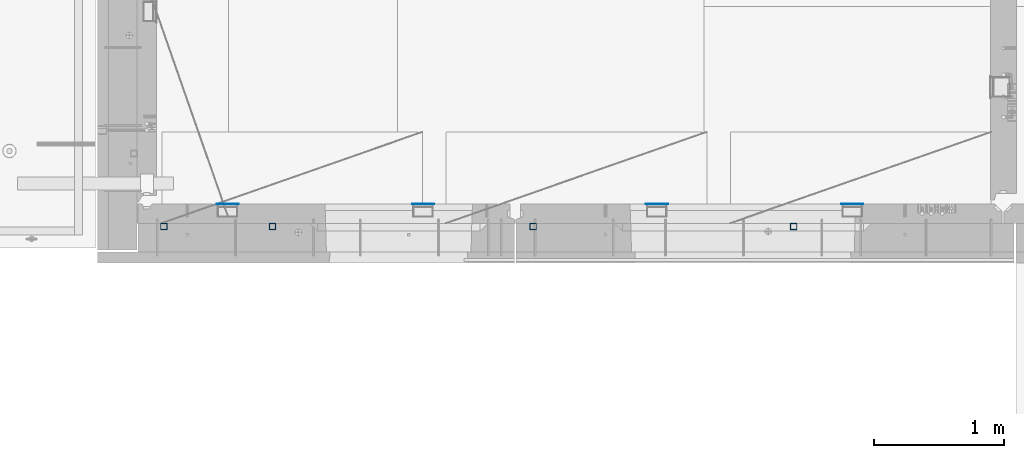
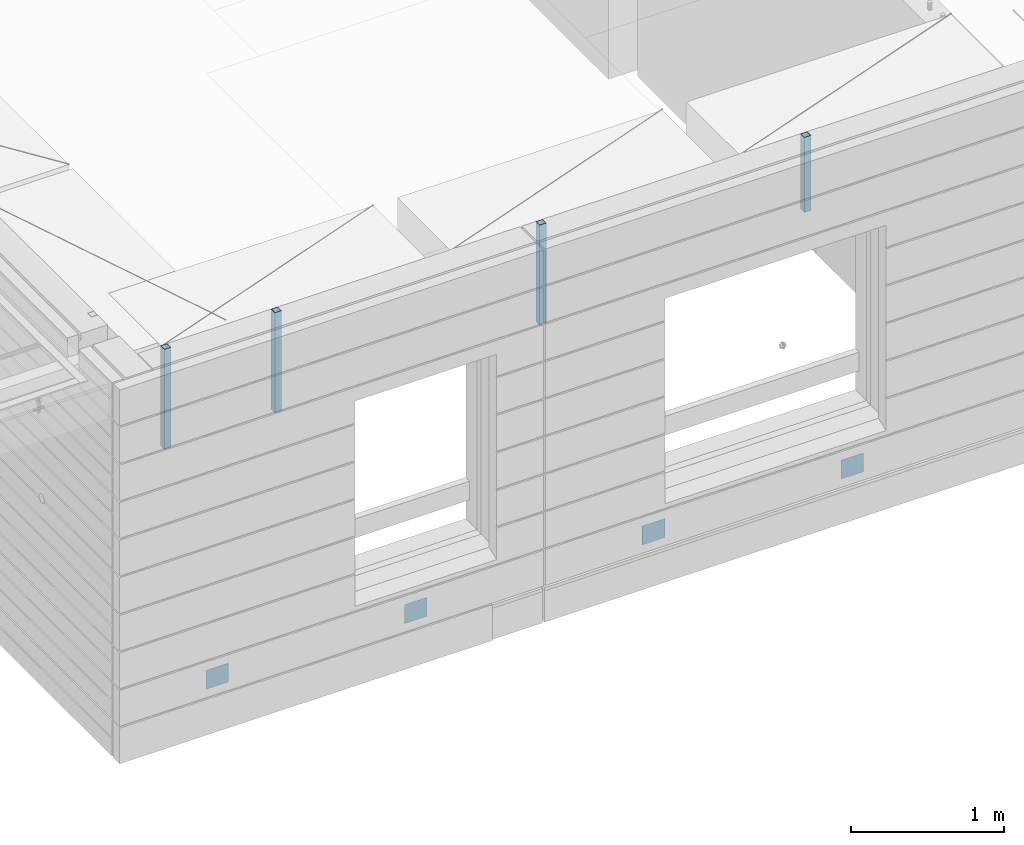
# One storey, part 9 of 350: 8 columns, 10 elements without a shape of their own.
"""IFC2X3 building model written with IfcOpenShell, lengths in millimetres."""

from ifc_helpers import new_model, si_unit, frame, origin_with_axes, place, context, subcontext, project, spatial, faceted_brep, material, type_object, element, aggregate, save


model = new_model("IFC2X3")

# Units and contexts
model_context = context("Model", 3, precision=1e-05, world=origin_with_axes())
body_context = subcontext(model_context, "Body", "Model", "MODEL_VIEW")
ifc_project = project(units=[si_unit("LENGTHUNIT", "METRE", prefix="MILLI"), si_unit("AREAUNIT", "SQUARE_METRE"), si_unit("VOLUMEUNIT", "CUBIC_METRE"), si_unit("MASSUNIT", "GRAM", prefix="KILO"), si_unit("TIMEUNIT", "SECOND"), si_unit("PLANEANGLEUNIT", "RADIAN"), si_unit("SOLIDANGLEUNIT", "STERADIAN"), si_unit("THERMODYNAMICTEMPERATUREUNIT", "DEGREE_CELSIUS"), si_unit("LUMINOUSINTENSITYUNIT", "LUMEN")], contexts=[model_context])

# Site, building, storey
site_placement = place(None, origin_with_axes())
site = spatial("IfcSite", under=ifc_project, at=site_placement, CompositionType="ELEMENT")
building_placement = place(site_placement, origin_with_axes())
building = spatial("IfcBuilding", under=site, at=building_placement, CompositionType="ELEMENT")
storey_placement = place(building_placement, origin_with_axes())
storey = spatial("IfcBuildingStorey", under=building, at=storey_placement, Name="2", CompositionType="ELEMENT", Elevation=0.0)

# Assemblies, columns
assembly_1_placement = place(storey_placement, origin_with_axes())
assembly_1 = element("IfcElementAssembly", 1, at=assembly_1_placement, inside=storey, AssemblyPlace="NOTDEFINED", PredefinedType="REINFORCEMENT_UNIT")
assembly_2_placement = place(assembly_1_placement, origin_with_axes())
assembly_2 = element("IfcElementAssembly", 2, at=assembly_2_placement, Name="Steel Assembly", AssemblyPlace="NOTDEFINED", PredefinedType="NOTDEFINED")
ifc_material_1 = material(Name="Undefined")
column_type_1 = type_object("IfcColumnType", PredefinedType="NOTDEFINED")
column_1_placement = place(assembly_2_placement, frame((10705.0, 7999.00000000618, 84755.0), z_axis=(0.0, 1.0, 0.0), x_axis=(0.0, 0.0, 1.0)))
column_1 = element("IfcColumn", 3, at=column_1_placement, type_object=column_type_1, material=ifc_material_1, Name="SPK2", context=body_context, shape_type="Brep", body=[
    faceted_brep([(0.0, 85.0, -1.0), (0.0, 85.0, 1.0), (150.0, 85.0, 1.0), (150.0, 85.0, -1.0), (0.0, -85.0, 1.0), (150.0, -85.0, 1.0), (0.0, -85.0, -1.0), (150.0, -85.0, -1.0)], [[[0, 1, 2, 3]], [[1, 4, 5, 2]], [[4, 6, 7, 5]], [[6, 0, 3, 7]], [[5, 7, 3, 2]], [[6, 4, 1, 0]]]),
])
aggregate(assembly_2, [column_1])
assembly_3_placement = place(assembly_1_placement, origin_with_axes())
assembly_3 = element("IfcElementAssembly", 4, at=assembly_3_placement, Name="Steel Assembly", AssemblyPlace="NOTDEFINED", PredefinedType="NOTDEFINED")
column_2_placement = place(assembly_3_placement, frame((12205.0, 7999.00000000618, 84755.0), z_axis=(0.0, 1.0, 0.0), x_axis=(0.0, 0.0, 1.0)))
column_2 = element("IfcColumn", 5, at=column_2_placement, type_object=column_type_1, material=ifc_material_1, Name="SPK2", context=body_context, shape_type="Brep", body=[
    faceted_brep([(0.0, 85.0, -1.0), (0.0, 85.0, 1.0), (150.0, 85.0, 1.0), (150.0, 85.0, -1.0), (0.0, -85.0, 1.0), (150.0, -85.0, 1.0), (0.0, -85.0, -1.0), (150.0, -85.0, -1.0)], [[[0, 1, 2, 3]], [[1, 4, 5, 2]], [[4, 6, 7, 5]], [[6, 0, 3, 7]], [[5, 7, 3, 2]], [[6, 4, 1, 0]]]),
])
aggregate(assembly_3, [column_2])

assembly_4_placement = place(storey_placement, origin_with_axes())
assembly_4 = element("IfcElementAssembly", 6, at=assembly_4_placement, inside=storey, AssemblyPlace="NOTDEFINED", PredefinedType="REINFORCEMENT_UNIT")
assembly_5_placement = place(assembly_4_placement, origin_with_axes())
assembly_5 = element("IfcElementAssembly", 7, at=assembly_5_placement, Name="Steel Assembly", AssemblyPlace="NOTDEFINED", PredefinedType="NOTDEFINED")
column_3_placement = place(assembly_5_placement, frame((14000.0, 7999.00000000618, 84755.0), z_axis=(0.0, 1.0, 0.0), x_axis=(0.0, 0.0, 1.0)))
column_3 = element("IfcColumn", 8, at=column_3_placement, type_object=column_type_1, material=ifc_material_1, Name="SPK2", context=body_context, shape_type="Brep", body=[
    faceted_brep([(0.0, 85.0, -1.0), (0.0, 85.0, 1.0), (150.0, 85.0, 1.0), (150.0, 85.0, -1.0), (0.0, -85.0, 1.0), (150.0, -85.0, 1.0), (0.0, -85.0, -1.0), (150.0, -85.0, -1.0)], [[[0, 1, 2, 3]], [[1, 4, 5, 2]], [[4, 6, 7, 5]], [[6, 0, 3, 7]], [[5, 7, 3, 2]], [[6, 4, 1, 0]]]),
])
aggregate(assembly_5, [column_3])
assembly_6_placement = place(assembly_4_placement, origin_with_axes())
assembly_6 = element("IfcElementAssembly", 9, at=assembly_6_placement, Name="Steel Assembly", AssemblyPlace="NOTDEFINED", PredefinedType="NOTDEFINED")
column_4_placement = place(assembly_6_placement, frame((15500.0, 7998.99999999844, 84754.9999999985), z_axis=(0.0, 1.0, 0.0), x_axis=(0.0, 0.0, 1.0)))
column_4 = element("IfcColumn", 10, at=column_4_placement, type_object=column_type_1, material=ifc_material_1, Name="SPK2", context=body_context, shape_type="Brep", body=[
    faceted_brep([(0.0, 85.0, -1.0), (0.0, 85.0, 1.0), (150.0, 85.0, 1.0), (150.0, 85.0, -1.0), (0.0, -85.0, 1.0), (150.0, -85.0, 1.0), (0.0, -85.0, -1.0), (150.0, -85.0, -1.0)], [[[0, 1, 2, 3]], [[1, 4, 5, 2]], [[4, 6, 7, 5]], [[6, 0, 3, 7]], [[5, 7, 3, 2]], [[6, 4, 1, 0]]]),
])
aggregate(assembly_6, [column_4])

# Assembly, column
assembly_7_placement = place(assembly_1_placement, origin_with_axes())
assembly_7 = element("IfcElementAssembly", 11, at=assembly_7_placement, Name="Steel Assembly", AssemblyPlace="NOTDEFINED", PredefinedType="RIGID_FRAME")
ifc_material_2 = material(Name="STEEL/S355J2")
column_type_2 = type_object("IfcColumnType", Name="50X50X3", PredefinedType="NOTDEFINED")
column_5_placement = place(assembly_7_placement, frame((11050.0, 7825.0, 86940.0), z_axis=(-1.0, 3.00000001838171e-08, 0.0), x_axis=(0.0, 0.0, 1.0)))
column_5 = element("IfcColumn", 12, at=column_5_placement, type_object=column_type_2, material=ifc_material_2, ObjectType="50X50X3", context=body_context, shape_type="Brep", body=[
    faceted_brep([(0.0, 22.0, -22.0), (0.0, -22.0, -22.0), (800.0, -22.0, -22.0), (800.0, 22.0, -22.0), (0.0, -22.0, 22.0), (800.0, -22.0, 22.0), (0.0, 22.0, 22.0), (800.0, 22.0, 22.0), (0.0, 25.0, -25.0), (0.0, 25.0, 25.0), (800.0, 25.0, 25.0), (800.0, 25.0, -25.0), (0.0, -25.0, 25.0), (800.0, -25.0, 25.0), (0.0, -25.0, -25.0), (800.0, -25.0, -25.0)], [[[0, 1, 2, 3]], [[1, 4, 5, 2]], [[4, 6, 7, 5]], [[6, 0, 3, 7]], [[8, 9, 10, 11]], [[9, 12, 13, 10]], [[12, 14, 15, 13]], [[14, 8, 11, 15]], [[13, 15, 11, 10], [5, 7, 3, 2]], [[14, 12, 9, 8], [6, 4, 1, 0]]]),
])
aggregate(assembly_7, [column_5])

assembly_8_placement = place(assembly_4_placement, origin_with_axes())
assembly_8 = element("IfcElementAssembly", 13, at=assembly_8_placement, Name="Steel Assembly", AssemblyPlace="NOTDEFINED", PredefinedType="RIGID_FRAME")
column_6_placement = place(assembly_8_placement, frame((13050.0, 7825.0, 86940.0), z_axis=(-1.0, 3.00000001838171e-08, 0.0), x_axis=(0.0, 0.0, 1.0)))
column_6 = element("IfcColumn", 14, at=column_6_placement, type_object=column_type_2, material=ifc_material_2, ObjectType="50X50X3", context=body_context, shape_type="Brep", body=[
    faceted_brep([(0.0, 22.0, -22.0), (0.0, -22.0, -22.0), (800.0, -22.0, -22.0), (800.0, 22.0, -22.0), (0.0, -22.0, 22.0), (800.0, -22.0, 22.0), (0.0, 22.0, 22.0), (800.0, 22.0, 22.0), (0.0, 25.0, -25.0), (0.0, 25.0, 25.0), (800.0, 25.0, 25.0), (800.0, 25.0, -25.0), (0.0, -25.0, 25.0), (800.0, -25.0, 25.0), (0.0, -25.0, -25.0), (800.0, -25.0, -25.0)], [[[0, 1, 2, 3]], [[1, 4, 5, 2]], [[4, 6, 7, 5]], [[6, 0, 3, 7]], [[8, 9, 10, 11]], [[9, 12, 13, 10]], [[12, 14, 15, 13]], [[14, 8, 11, 15]], [[13, 15, 11, 10], [5, 7, 3, 2]], [[14, 12, 9, 8], [6, 4, 1, 0]]]),
])
aggregate(assembly_8, [column_6])

# Assembly
assembly_9_placement = place(assembly_4_placement, origin_with_axes())
assembly_9 = element("IfcElementAssembly", 15, at=assembly_9_placement, Name="Steel Assembly", AssemblyPlace="NOTDEFINED", PredefinedType="RIGID_FRAME")

aggregate(assembly_4, [assembly_8, assembly_9, assembly_5, assembly_6])

# Column
column_7_placement = place(assembly_9_placement, frame((15050.0, 7825.0, 87140.0), z_axis=(-1.0, 3.00000001838171e-08, 0.0), x_axis=(0.0, 0.0, 1.0)))
column_7 = element("IfcColumn", 16, at=column_7_placement, type_object=column_type_2, material=ifc_material_2, ObjectType="50X50X3", context=body_context, shape_type="Brep", body=[
    faceted_brep([(0.0, 22.0, -22.0), (0.0, -22.0, -22.0), (600.0, -22.0, -22.0), (600.0, 22.0, -22.0), (0.0, -22.0, 22.0), (600.0, -22.0, 22.0), (0.0, 22.0, 22.0), (600.0, 22.0, 22.0), (0.0, 25.0, -25.0), (0.0, 25.0, 25.0), (600.0, 25.0, 25.0), (600.0, 25.0, -25.0), (0.0, -25.0, 25.0), (600.0, -25.0, 25.0), (0.0, -25.0, -25.0), (600.0, -25.0, -25.0)], [[[0, 1, 2, 3]], [[1, 4, 5, 2]], [[4, 6, 7, 5]], [[6, 0, 3, 7]], [[8, 9, 10, 11]], [[9, 12, 13, 10]], [[12, 14, 15, 13]], [[14, 8, 11, 15]], [[13, 15, 11, 10], [5, 7, 3, 2]], [[14, 12, 9, 8], [6, 4, 1, 0]]]),
])

aggregate(assembly_9, [column_7])

# Assembly
assembly_10_placement = place(assembly_1_placement, origin_with_axes())
assembly_10 = element("IfcElementAssembly", 17, at=assembly_10_placement, Name="Steel Assembly", AssemblyPlace="NOTDEFINED", PredefinedType="RIGID_FRAME")

aggregate(assembly_1, [assembly_7, assembly_2, assembly_3, assembly_10])

# Column
column_8_placement = place(assembly_10_placement, frame((10215.0, 7825.0, 86940.0), z_axis=(-1.0, 3.00000001838171e-08, 0.0), x_axis=(0.0, 0.0, 1.0)))
column_8 = element("IfcColumn", 18, at=column_8_placement, type_object=column_type_2, material=ifc_material_2, ObjectType="50X50X3", context=body_context, shape_type="Brep", body=[
    faceted_brep([(0.0, 22.0, -22.0), (0.0, -22.0, -22.0), (800.0, -22.0, -22.0), (800.0, 22.0, -22.0), (0.0, -22.0, 22.0), (800.0, -22.0, 22.0), (0.0, 22.0, 22.0), (800.0, 22.0, 22.0), (0.0, 25.0, -25.0), (0.0, 25.0, 25.0), (800.0, 25.0, 25.0), (800.0, 25.0, -25.0), (0.0, -25.0, 25.0), (800.0, -25.0, 25.0), (0.0, -25.0, -25.0), (800.0, -25.0, -25.0)], [[[0, 1, 2, 3]], [[1, 4, 5, 2]], [[4, 6, 7, 5]], [[6, 0, 3, 7]], [[8, 9, 10, 11]], [[9, 12, 13, 10]], [[12, 14, 15, 13]], [[14, 8, 11, 15]], [[13, 15, 11, 10], [5, 7, 3, 2]], [[14, 12, 9, 8], [6, 4, 1, 0]]]),
])

aggregate(assembly_10, [column_8])

save(model, "model.ifc")
